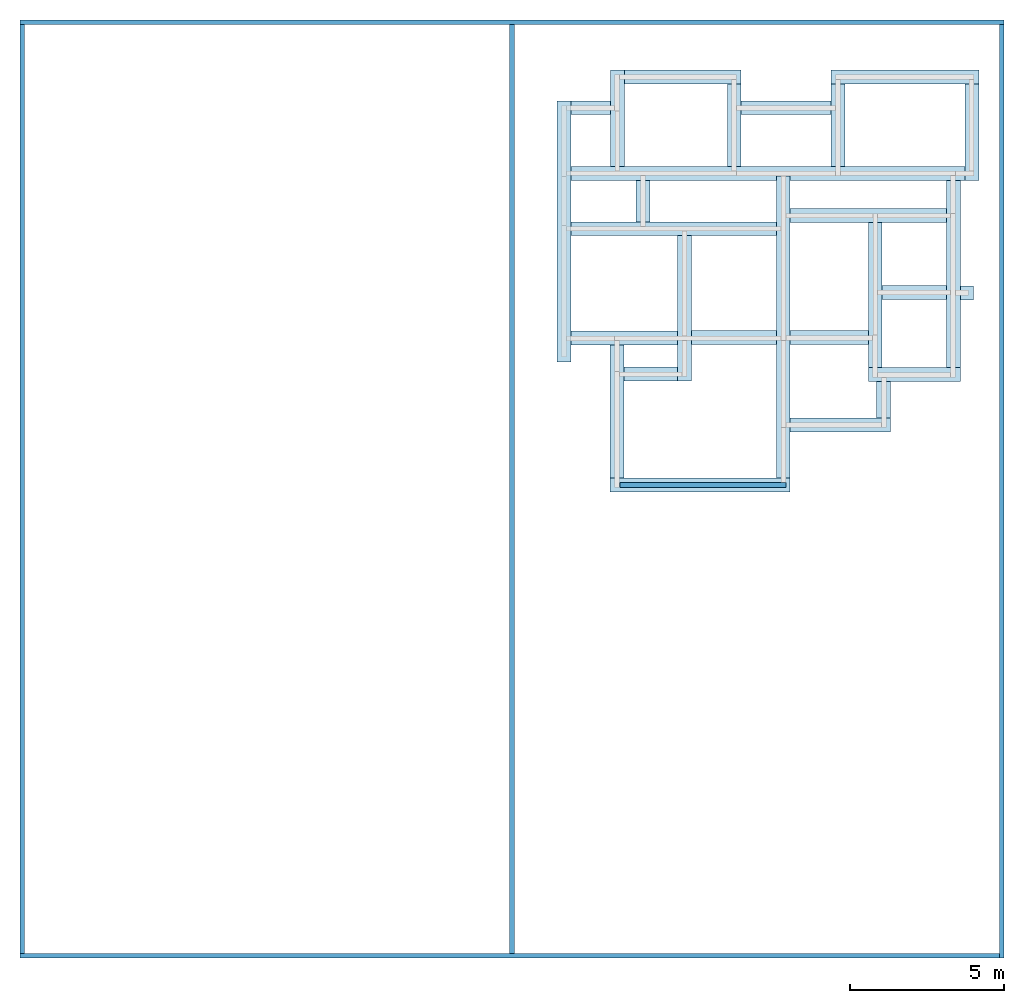
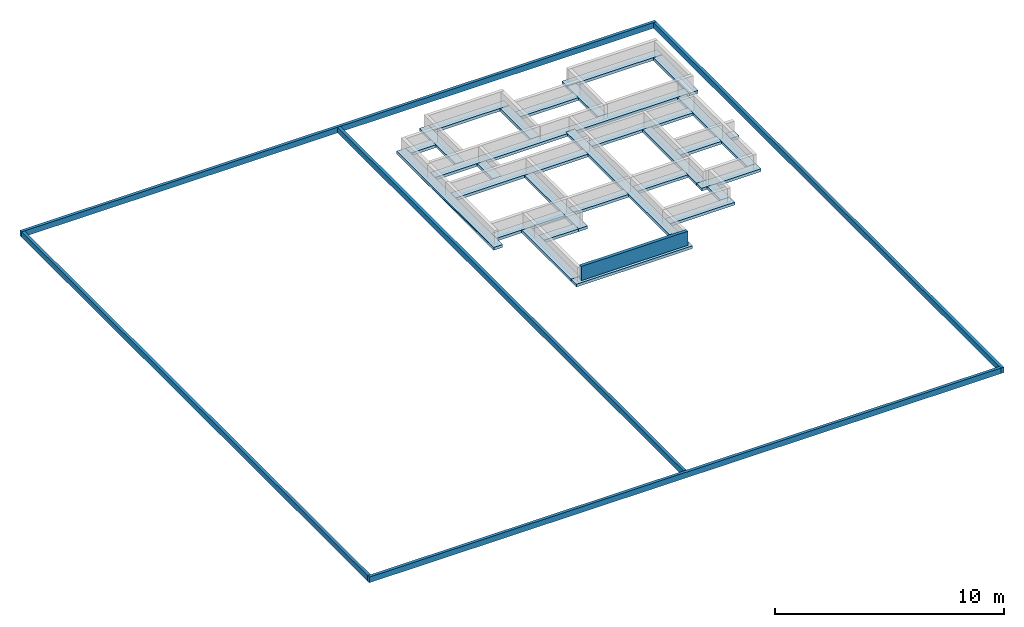
# One storey, part 1 of 2: 29 footings, 6 walls.
"""IFC4 building model written with IfcOpenShell, lengths in millimetres."""

from ifc_helpers import new_model, entity, si_unit, converted_unit, frame, origin_with_axes, origin_2d_with_axis, place, context, subcontext, project, spatial, indexed_curve, outline, extrude, polygons, material, layer, layer_set, layer_usage, type_object, element, save


model = new_model("IFC4")

# Units and contexts
model_context = context("Model", 3, precision=1e-05, world=origin_with_axes())
plan_context = context("Plan", 2, precision=1e-05, world=origin_2d_with_axis())
body_context = subcontext(model_context, "Body", "Model", "MODEL_VIEW")
ifc_project = project(units=[si_unit("LENGTHUNIT", "METRE", prefix="MILLI"), converted_unit("PLANEANGLEUNIT", "degree", entity("IfcReal", 0.0174532925199433), si_unit("PLANEANGLEUNIT", "RADIAN"), dimensions=[0, 0, 0, 0, 0, 0, 0]), si_unit("AREAUNIT", "SQUARE_METRE"), si_unit("VOLUMEUNIT", "CUBIC_METRE")], contexts=[model_context, plan_context])

# Site, building, storey
site_placement = place(None, origin_with_axes())
site = spatial("IfcSite", under=ifc_project, at=site_placement)
building_placement = place(site_placement, origin_with_axes())
building = spatial("IfcBuilding", under=site, at=building_placement, Name="Building")
storey_placement = place(building_placement, frame((0.0, 0.0, -900.000035762787), z_axis=(0.0, 0.0, 1.0), x_axis=(1.0, 0.0, 0.0)))
storey = spatial("IfcBuildingStorey", under=building, at=storey_placement, Name="FOUNDATION PLAN")

# Footings
ifc_material_1 = material(Name="Concrete - Common In-situ", Category="In-situ Concrete/ Large Precast Concrete")
footing_1_placement = place(storey_placement, frame((8774.75070953369, 14656.0354232788, -75.0000476837157), z_axis=(0.0, 0.0, 1.0), x_axis=(1.0, 0.0, 0.0)))
element("IfcFooting", 1, at=footing_1_placement, inside=storey, material=ifc_material_1, Name="Cube", PredefinedType="STRIP_FOOTING", context=body_context, shape_type="Tessellation", body=[
    polygons([(-224.999984741211, -1691.21069335938, -75.0), (-224.999984741211, 999.999877929688, -75.0), (-224.999984741211, -1691.21069335938, 75.0), (-224.999984741211, 999.999877929688, 75.0), (224.999984741211, 999.999877929688, -75.0), (224.999984741211, 999.999877929688, 75.0), (224.999984741211, -1691.21069335938, -75.0), (224.999984741211, -1691.21069335938, 75.0)], [[[3, 2, 1]], [[3, 4, 2]], [[6, 5, 2]], [[6, 2, 4]], [[6, 7, 5]], [[6, 8, 7]], [[7, 8, 3]], [[7, 3, 1]], [[1, 2, 5]], [[1, 5, 7]], [[4, 8, 6]], [[4, 3, 8]]], closed=True),
])
footing_2_placement = place(storey_placement, frame((6990.45419692993, 11664.831161499, -74.9999880790709), z_axis=(0.0, 0.0, 1.0), x_axis=(1.0, 0.0, 0.0)))
element("IfcFooting", 2, at=footing_2_placement, inside=storey, material=ifc_material_1, Name="Cube", PredefinedType="STRIP_FOOTING", context=body_context, shape_type="Tessellation", body=[
    polygons([(-224.999984741211, -8821.1494140625, -75.0), (-224.999984741211, 999.999877929688, -75.0), (-224.999984741211, -8821.1494140625, 75.0), (-224.999984741211, 999.999877929688, 75.0), (224.999984741211, 999.999877929688, -75.0), (224.999984741211, 999.999877929688, 75.0), (224.999984741211, -8821.1494140625, -75.0), (224.999984741211, -8821.1494140625, 75.0)], [[[3, 2, 1]], [[3, 4, 2]], [[6, 5, 2]], [[6, 2, 4]], [[6, 7, 5]], [[6, 8, 7]], [[7, 8, 3]], [[7, 3, 1]], [[1, 2, 5]], [[1, 5, 7]], [[4, 8, 6]], [[4, 3, 8]]], closed=True),
])
footing_3_placement = place(storey_placement, frame((13123.2786178589, 14656.0354232788, -75.0000476837157), z_axis=(0.0, 0.0, 1.0), x_axis=(1.0, 0.0, 0.0)))
element("IfcFooting", 3, at=footing_3_placement, inside=storey, material=ifc_material_1, Name="Cube", PredefinedType="STRIP_FOOTING", context=body_context, shape_type="Tessellation", body=[
    polygons([(-224.999984741211, -2141.21142578125, -75.0), (-224.999984741211, 999.999877929688, -75.0), (-224.999984741211, -2141.2109375, 75.0), (-224.999984741211, 999.999877929688, 75.0), (224.999984741211, 999.999877929688, -75.0), (224.999984741211, 999.999877929688, 75.0), (224.999984741211, -2141.21142578125, -75.0), (224.999984741211, -2141.2109375, 75.0)], [[[2, 4, 6, 5]], [[6, 8, 7, 5]], [[5, 7, 1, 2]], [[3, 8, 6, 4]], [[7, 8, 3, 1]], [[3, 4, 2, 1]]], closed=True),
])
footing_4_placement = place(storey_placement, frame((9099.74956512451, 12739.8242950439, -75.0000476837157), z_axis=(0.0, 0.0, 1.0), x_axis=(-4.37113882867379e-08, -0.999999999999999, 0.0)))
element("IfcFooting", 4, at=footing_4_placement, inside=storey, material=ifc_material_1, Name="Cube", PredefinedType="STRIP_FOOTING", context=body_context, shape_type="Tessellation", body=[
    polygons([(-225.000595092773, -9010.2783203125, -75.0), (-224.999771118164, 3798.5283203125, -75.0), (-224.999618530273, -9010.2783203125, 75.0), (-225.000106811523, 3798.5283203125, 75.0), (225.000183105469, 3798.5283203125, -75.0), (224.999862670898, 3798.5283203125, 75.0), (224.999374389648, -9010.2783203125, -75.0), (225.000335693359, -9010.2783203125, 75.0)], [[[6, 5, 2, 4]], [[5, 7, 1, 2]], [[3, 8, 6, 4]], [[8, 7, 5, 6]], [[7, 8, 3, 1]], [[2, 1, 3, 4]]], closed=True),
])
footing_5_placement = place(storey_placement, frame((-135.529160499573, 14103.9342880249, -74.9999284744262), z_axis=(0.0, 0.0, 1.0), x_axis=(1.0, 0.0, 0.0)))
element("IfcFooting", 5, at=footing_5_placement, inside=storey, material=ifc_material_1, Name="Cube", PredefinedType="STRIP_FOOTING", context=body_context, shape_type="Tessellation", body=[
    polygons([(-224.999984741211, -7482.92724609375, -75.0), (-224.999984741211, 999.999877929688, -75.0), (-224.999984741211, -7482.92724609375, 75.0), (-224.999984741211, 999.999877929688, 75.0), (224.999984741211, 999.999877929688, -75.0), (224.999984741211, 999.999877929688, 75.0), (224.999984741211, -7482.92724609375, -75.0), (224.999984741211, -7482.92724609375, 75.0)], [[[1, 4, 2]], [[3, 4, 1]], [[6, 5, 2]], [[6, 2, 4]], [[5, 8, 7]], [[6, 8, 5]], [[7, 8, 3]], [[7, 3, 1]], [[1, 2, 5]], [[1, 5, 7]], [[4, 8, 6]], [[4, 3, 8]]], closed=True),
])
footing_6_placement = place(storey_placement, frame((-135.529160499573, 14103.9342880249, -74.9999284744262), z_axis=(0.0, 0.0, 1.0), x_axis=(1.0, 0.0, 0.0)))
element("IfcFooting", 6, at=footing_6_placement, inside=storey, material=ifc_material_1, Name="Cube", PredefinedType="STRIP_FOOTING", context=body_context, shape_type="Tessellation", body=[
    polygons([(-224.999984741211, -999.999877929688, -75.0), (-224.999984741211, 999.999877929688, -75.0), (-224.999984741211, -7482.92724609375, 75.0), (-224.999984741211, 999.999877929688, 75.0), (224.999984741211, 999.999877929688, -75.0), (224.999984741211, 999.999877929688, 75.0), (224.999984741211, -999.999877929688, -75.0), (224.999984741211, -7482.92724609375, 75.0)], [[[1, 4, 2]], [[3, 4, 1]], [[6, 5, 2]], [[6, 2, 4]], [[7, 5, 6]], [[6, 8, 7]], [[3, 1, 7]], [[3, 7, 8]], [[1, 2, 5]], [[1, 5, 7]], [[4, 8, 6]], [[4, 3, 8]]], closed=True),
])
footing_7_placement = place(storey_placement, frame((1598.79803657532, 15106.0352325439, -74.9999880790709), z_axis=(0.0, 0.0, 1.0), x_axis=(1.0, 0.0, 0.0)))
element("IfcFooting", 7, at=footing_7_placement, inside=storey, material=ifc_material_1, Name="Cube", PredefinedType="STRIP_FOOTING", context=body_context, shape_type="Tessellation", body=[
    polygons([(-224.999984741211, -2141.21044921875, -75.0), (-224.999984741211, 999.999877929688, -75.0), (-224.999984741211, -2141.21044921875, 75.0), (-224.999984741211, 999.999877929688, 75.0), (224.999984741211, 999.999877929688, -75.0), (224.999984741211, 999.999877929688, 75.0), (224.999984741211, -2141.21044921875, -75.0), (224.999984741211, -2141.21044921875, 75.0)], [[[2, 4, 6, 5]], [[6, 8, 7, 5]], [[5, 7, 1, 2]], [[3, 8, 6, 4]], [[7, 8, 3, 1]], [[3, 4, 2, 1]]], closed=True),
])
footing_8_placement = place(storey_placement, frame((2823.79817962646, 15881.0358047485, -74.9999880790709), z_axis=(0.0, 0.0, 1.0), x_axis=(-4.37113882867379e-08, -0.999999999999999, 0.0)))
element("IfcFooting", 8, at=footing_8_placement, inside=storey, material=ifc_material_1, Name="Cube", PredefinedType="STRIP_FOOTING", context=body_context, shape_type="Tessellation", body=[
    polygons([(-224.999984741211, -999.999877929688, -75.0), (-225.000076293945, 2799.47338867188, -75.0), (-224.999984741211, -999.999877929688, 75.0), (-225.000076293945, 2799.47338867188, 75.0), (224.999908447266, 2799.47338867188, -75.0), (224.999908447266, 2799.47338867188, 75.0), (224.999984741211, -999.999877929688, -75.0), (224.999984741211, -999.999877929688, 75.0)], [[[3, 2, 1]], [[3, 4, 2]], [[6, 5, 2]], [[6, 2, 4]], [[6, 7, 5]], [[6, 8, 7]], [[7, 8, 3]], [[7, 3, 1]], [[1, 2, 5]], [[1, 5, 7]], [[6, 3, 8]], [[4, 3, 6]]], closed=True),
])
footing_9_placement = place(storey_placement, frame((5398.2720375061, 14656.0354232788, -74.9999880790709), z_axis=(0.0, 0.0, 1.0), x_axis=(1.0, 0.0, 0.0)))
element("IfcFooting", 9, at=footing_9_placement, inside=storey, material=ifc_material_1, Name="Cube", PredefinedType="STRIP_FOOTING", context=body_context, shape_type="Tessellation", body=[
    polygons([(-224.999984741211, -1691.21069335938, -75.0), (-224.999984741211, 999.999877929688, -75.0), (-224.999984741211, -1691.21069335938, 75.0), (-224.999984741211, 999.999877929688, 75.0), (224.999984741211, 999.999877929688, -75.0), (224.999984741211, 999.999877929688, 75.0), (224.999984741211, -1691.21069335938, -75.0), (224.999984741211, -1691.21069335938, 75.0)], [[[3, 2, 1]], [[3, 4, 2]], [[6, 5, 2]], [[6, 2, 4]], [[6, 7, 5]], [[6, 8, 7]], [[7, 8, 3]], [[7, 3, 1]], [[1, 2, 5]], [[1, 5, 7]], [[4, 8, 6]], [[4, 3, 8]]], closed=True),
])
footing_10_placement = place(storey_placement, frame((1089.47086334229, 14878.9339065552, -74.9999284744262), z_axis=(0.0, 0.0, 1.0), x_axis=(-4.37113882867379e-08, -0.999999999999999, 0.0)))
element("IfcFooting", 10, at=footing_10_placement, inside=storey, material=ifc_material_1, Name="Cube", PredefinedType="STRIP_FOOTING", context=body_context, shape_type="Tessellation", body=[
    polygons([(-224.999984741211, -999.999877929688, -75.0), (-224.999954223633, 284.327026367188, -75.0), (-224.999984741211, -999.999877929688, 75.0), (-224.999954223633, 284.327026367188, 75.0), (225.000015258789, 284.327026367188, -75.0), (225.000015258789, 284.327026367188, 75.0), (224.999984741211, -999.999877929688, -75.0), (224.999984741211, -999.999877929688, 75.0)], [[[3, 2, 1]], [[3, 4, 2]], [[6, 5, 2]], [[6, 2, 4]], [[6, 7, 5]], [[6, 8, 7]], [[7, 8, 3]], [[7, 3, 1]], [[2, 5, 7]], [[2, 7, 1]], [[4, 3, 8]], [[6, 4, 8]]], closed=True),
])
footing_11_placement = place(storey_placement, frame((8636.25144958496, 11373.3215332031, -74.9999880790709), z_axis=(0.0, 0.0, 1.0), x_axis=(-4.37113882867379e-08, -0.999999999999999, 0.0)))
element("IfcFooting", 11, at=footing_11_placement, inside=storey, material=ifc_material_1, Name="Cube", PredefinedType="STRIP_FOOTING", context=body_context, shape_type="Tessellation", body=[
    polygons([(-224.999954223633, -1420.79650878906, -75.0), (-225.000106811523, 3662.02978515625, -75.0), (-225.000106811523, 3662.02880859375, 75.0), (-224.999954223633, -1420.79650878906, 75.0), (224.99983215332, 3662.02880859375, 75.0), (224.99983215332, 3662.02978515625, -75.0), (224.999984741211, -1420.79650878906, -75.0), (224.999984741211, -1420.79650878906, 75.0)], [[[1, 3, 2]], [[4, 3, 1]], [[5, 6, 2]], [[5, 2, 3]], [[5, 7, 6]], [[5, 8, 7]], [[7, 8, 4]], [[7, 4, 1]], [[6, 7, 1]], [[2, 6, 1]], [[5, 3, 4]], [[5, 4, 8]]], closed=True),
])
footing_12_placement = place(storey_placement, frame((8486.24897003174, 8873.00109863281, -74.9999880790709), z_axis=(0.0, 0.0, 1.0), x_axis=(7.54979012640431e-08, -0.999999999999997, 0.0)))
element("IfcFooting", 12, at=footing_12_placement, inside=storey, material=ifc_material_1, Name="Cube", PredefinedType="STRIP_FOOTING", context=body_context, shape_type="Tessellation", body=[
    polygons([(-225.000106811523, 1720.51416015625, -75.0), (-225.000106811523, 3812.03247070312, -75.0), (-225.000106811523, 1720.51416015625, 75.0), (-225.000106811523, 3812.03125, 75.0), (224.999862670898, 3812.03247070312, -75.0), (224.999862670898, 3812.03125, 75.0), (224.999862670898, 1720.51416015625, -75.0), (224.999862670898, 1720.51416015625, 75.0)], [[[2, 4, 6, 5]], [[8, 7, 5, 6]], [[5, 7, 1, 2]], [[3, 8, 6, 4]], [[8, 3, 1, 7]], [[4, 2, 1, 3]]], closed=True),
])
footing_13_placement = place(storey_placement, frame((1510.26773452759, 10943.3317184448, -74.9998688697814), z_axis=(0.0, 0.0, 1.0), x_axis=(-4.37113882867379e-08, -0.999999999999999, 0.0)))
element("IfcFooting", 13, at=footing_13_placement, inside=storey, material=ifc_material_1, Name="Cube", PredefinedType="STRIP_FOOTING", context=body_context, shape_type="Tessellation", body=[
    polygons([(-224.999969482422, -1420.79663085938, -75.0), (-225.000152587891, 5255.18701171875, -75.0), (-224.999969482422, -1420.79663085938, 75.0), (-225.000152587891, 5255.185546875, 75.0), (224.999801635742, 5255.18701171875, -75.0), (224.999801635742, 5255.185546875, 75.0), (225.0, -1420.79663085938, -75.0), (225.0, -1420.79663085938, 75.0)], [[[1, 4, 2]], [[3, 4, 1]], [[6, 5, 2]], [[6, 2, 4]], [[6, 7, 5]], [[6, 8, 7]], [[7, 8, 3]], [[7, 3, 1]], [[5, 7, 1]], [[2, 5, 1]], [[6, 4, 3]], [[6, 3, 8]]], closed=True),
])
footing_14_placement = place(storey_placement, frame((9981.76288604736, 10148.3211517334, -74.9999880790709), z_axis=(0.0, 0.0, 1.0), x_axis=(1.0, 0.0, 0.0)))
element("IfcFooting", 14, at=footing_14_placement, inside=storey, material=ifc_material_1, Name="Cube", PredefinedType="STRIP_FOOTING", context=body_context, shape_type="Tessellation", body=[
    polygons([(-224.999984741211, -3720.31640625, -75.0), (-224.999984741211, 999.999877929688, -75.0), (-224.999984741211, -3720.31640625, 75.0), (-224.999984741211, 999.999877929688, 75.0), (224.999984741211, 999.999877929688, -75.0), (224.999984741211, 999.999877929688, 75.0), (224.999984741211, -3720.31640625, -75.0), (224.999984741211, -3720.31640625, 75.0)], [[[3, 2, 1]], [[3, 4, 2]], [[6, 5, 2]], [[6, 2, 4]], [[6, 7, 5]], [[6, 8, 7]], [[7, 8, 3]], [[7, 3, 1]], [[2, 5, 7]], [[2, 7, 1]], [[6, 4, 3]], [[6, 3, 8]]], closed=True),
])
footing_15_placement = place(storey_placement, frame((12523.2810974121, 11514.8239135742, -74.9999880790709), z_axis=(0.0, 0.0, 1.0), x_axis=(1.0, 0.0, 0.0)))
element("IfcFooting", 15, at=footing_15_placement, inside=storey, material=ifc_material_1, Name="Cube", PredefinedType="STRIP_FOOTING", context=body_context, shape_type="Tessellation", body=[
    polygons([(-224.999984741211, -5086.81884765625, -75.0), (-224.999984741211, 999.999877929688, -75.0), (-224.999984741211, -5086.81884765625, 75.0), (-224.999984741211, 999.999877929688, 75.0), (224.999984741211, 999.999877929688, -75.0), (224.999984741211, 999.999877929688, 75.0), (224.999984741211, -5086.81884765625, -75.0), (224.999984741211, -5086.81884765625, 75.0)], [[[3, 2, 1]], [[3, 4, 2]], [[6, 5, 2]], [[6, 2, 4]], [[6, 7, 5]], [[6, 8, 7]], [[7, 8, 3]], [[7, 3, 1]], [[2, 5, 7]], [[2, 7, 1]], [[6, 4, 3]], [[6, 3, 8]]], closed=True),
])
footing_16_placement = place(storey_placement, frame((8486.24897003174, 6203.00436019897, -74.9999880790709), z_axis=(0.0, 0.0, 1.0), x_axis=(-4.37113882867379e-08, -0.999999999999999, 0.0)))
element("IfcFooting", 16, at=footing_16_placement, inside=storey, material=ifc_material_1, Name="Cube", PredefinedType="STRIP_FOOTING", context=body_context, shape_type="Tessellation", body=[
    polygons([(-225.000106811523, 1270.51342773438, -75.0), (-225.000106811523, 4262.03271484375, -75.0), (-225.000106811523, 1270.51342773438, 75.0), (-225.000106811523, 4262.03173828125, 75.0), (224.999847412109, 4262.03271484375, -75.0), (224.999847412109, 4262.03173828125, 75.0), (224.999877929688, 1270.51342773438, -75.0), (224.999877929688, 1270.51342773438, 75.0)], [[[1, 4, 2]], [[3, 4, 1]], [[6, 5, 2]], [[6, 2, 4]], [[6, 7, 5]], [[6, 8, 7]], [[7, 8, 3]], [[7, 3, 1]], [[5, 7, 1]], [[2, 5, 1]], [[6, 4, 3]], [[6, 3, 8]]], closed=True),
])
footing_17_placement = place(storey_placement, frame((3780.96985816956, 9718.3313369751, -74.9998688697814), z_axis=(0.0, 0.0, 1.0), x_axis=(1.0, 0.0, 0.0)))
element("IfcFooting", 17, at=footing_17_placement, inside=storey, material=ifc_material_1, Name="Cube", PredefinedType="STRIP_FOOTING", context=body_context, shape_type="Tessellation", body=[
    polygons([(-224.999984741211, -3720.31640625, -75.0), (-224.999984741211, 999.999877929688, -75.0), (-224.999984741211, -3720.31640625, 75.0), (-224.999984741211, 999.999877929688, 75.0), (224.999984741211, 999.999877929688, -75.0), (224.999984741211, 999.999877929688, 75.0), (224.999984741211, -3720.31640625, -75.0), (224.999984741211, -3720.31640625, 75.0)], [[[3, 2, 1]], [[3, 4, 2]], [[6, 5, 2]], [[6, 2, 4]], [[6, 7, 5]], [[6, 8, 7]], [[7, 8, 3]], [[7, 3, 1]], [[2, 5, 7]], [[2, 7, 1]], [[6, 4, 3]], [[6, 3, 8]]], closed=True),
])
footing_18_placement = place(storey_placement, frame((1510.26678085327, 7388.68141174316, -74.9999880790709), z_axis=(0.0, 0.0, 1.0), x_axis=(-4.37113882867379e-08, -0.999999999999999, 0.0)))
element("IfcFooting", 18, at=footing_18_placement, inside=storey, material=ifc_material_1, Name="Cube", PredefinedType="STRIP_FOOTING", context=body_context, shape_type="Tessellation", body=[
    polygons([(-224.999969482422, -1420.79663085938, -75.0), (-225.000030517578, 2045.70397949219, -75.0), (-224.999969482422, -1420.79663085938, 75.0), (-225.000030517578, 2045.70251464844, 75.0), (224.999938964844, 2045.70397949219, -75.0), (224.999938964844, 2045.70251464844, 75.0), (225.0, -1420.79663085938, -75.0), (225.0, -1420.79663085938, 75.0)], [[[1, 4, 2]], [[3, 4, 1]], [[6, 5, 2]], [[6, 2, 4]], [[6, 7, 5]], [[6, 8, 7]], [[7, 8, 3]], [[7, 3, 1]], [[5, 7, 1]], [[2, 5, 1]], [[6, 4, 3]], [[6, 3, 8]]], closed=True),
])
footing_19_placement = place(storey_placement, frame((4719.74992752075, 7404.99973297119, -74.9999880790709), z_axis=(0.0, 0.0, 1.0), x_axis=(-4.37113882867379e-08, -0.999999999999999, 0.0)))
element("IfcFooting", 19, at=footing_19_placement, inside=storey, material=ifc_material_1, Name="Cube", PredefinedType="STRIP_FOOTING", context=body_context, shape_type="Tessellation", body=[
    polygons([(-225.0, -713.779907226562, -75.0), (-225.000030517578, 2045.70397949219, -75.0), (-225.0, -713.779907226562, 75.0), (-225.000030517578, 2045.70251464844, 75.0), (224.999938964844, 2045.70397949219, -75.0), (224.999938964844, 2045.70251464844, 75.0), (224.999969482422, -713.779907226562, -75.0), (224.999969482422, -713.779907226562, 75.0)], [[[1, 4, 2]], [[3, 4, 1]], [[6, 5, 2]], [[6, 2, 4]], [[6, 7, 5]], [[6, 8, 7]], [[7, 8, 3]], [[7, 3, 1]], [[5, 7, 1]], [[2, 5, 1]], [[6, 4, 3]], [[6, 3, 8]]], closed=True),
])
footing_20_placement = place(storey_placement, frame((1584.99681949615, 6179.99982833862, -74.9999880790709), z_axis=(0.0, 0.0, 1.0), x_axis=(1.0, 0.0, 0.0)))
element("IfcFooting", 20, at=footing_20_placement, inside=storey, material=ifc_material_1, Name="Cube", PredefinedType="STRIP_FOOTING", context=body_context, shape_type="Tessellation", body=[
    polygons([(-224.999984741211, -3336.31811523438, -75.0), (-224.999984741211, 999.999877929688, -75.0), (-224.999984741211, -3336.31811523438, 75.0), (-224.999984741211, 999.999877929688, 75.0), (224.999984741211, 999.999877929688, -75.0), (224.999984741211, 999.999877929688, 75.0), (224.999984741211, -3336.31811523438, -75.0), (224.999984741211, -3336.31811523438, 75.0)], [[[3, 2, 1]], [[3, 4, 2]], [[6, 5, 2]], [[6, 2, 4]], [[6, 7, 5]], [[6, 8, 7]], [[7, 8, 3]], [[7, 3, 1]], [[1, 2, 5]], [[1, 5, 7]], [[4, 8, 6]], [[4, 3, 8]]], closed=True),
])
footing_21_placement = place(storey_placement, frame((-47.0151901245117, 6225.18110275269, -74.9999880790709), z_axis=(0.0, 0.0, 1.0), x_axis=(-4.37113882867379e-08, -0.999999999999999, 0.0)))
element("IfcFooting", 21, at=footing_21_placement, inside=storey, material=ifc_material_1, Name="Cube", PredefinedType="STRIP_FOOTING", context=body_context, shape_type="Tessellation", body=[
    polygons([(-225.000106811523, 1857.01196289062, -75.0), (-225.000106811523, 3602.98461914062, -75.0), (-225.000106811523, 1857.01196289062, 75.0), (-225.000106811523, 3602.9833984375, 75.0), (224.999877929688, 3602.98461914062, -75.0), (224.999877929688, 3602.9833984375, 75.0), (224.999862670898, 1857.01196289062, -75.0), (224.999862670898, 1857.01196289062, 75.0)], [[[1, 3, 4]], [[1, 4, 2]], [[6, 5, 2]], [[6, 2, 4]], [[6, 7, 5]], [[6, 8, 7]], [[1, 7, 8]], [[1, 8, 3]], [[2, 5, 7]], [[2, 7, 1]], [[4, 3, 8]], [[6, 4, 8]]], closed=True),
])
footing_22_placement = place(storey_placement, frame((4719.74992752075, 2618.68095397949, -74.9999880790709), z_axis=(0.0, 0.0, 1.0), x_axis=(-4.37113882867379e-08, -0.999999999999999, 0.0)))
element("IfcFooting", 22, at=footing_22_placement, inside=storey, material=ifc_material_1, Name="Cube", PredefinedType="STRIP_FOOTING", context=body_context, shape_type="Tessellation", body=[
    polygons([(-224.999877929688, -3359.75268554688, -75.0), (-225.000045776367, 2495.7041015625, -75.0), (-224.999877929688, -3359.75268554688, 75.0), (-225.000045776367, 2495.70263671875, 75.0), (224.999923706055, 2495.7041015625, -75.0), (224.999923706055, 2495.70263671875, 75.0), (225.000106811523, -3359.75268554688, -75.0), (225.000106811523, -3359.75268554688, 75.0)], [[[1, 4, 2]], [[3, 4, 1]], [[6, 5, 2]], [[6, 2, 4]], [[6, 7, 5]], [[6, 8, 7]], [[7, 8, 3]], [[7, 3, 1]], [[5, 7, 1]], [[2, 5, 1]], [[6, 4, 3]], [[6, 3, 8]]], closed=True),
])
footing_23_placement = place(storey_placement, frame((7711.05813980103, 7404.99973297119, -74.9999880790709), z_axis=(0.0, 0.0, 1.0), x_axis=(-4.37113882867379e-08, -0.999999999999999, 0.0)))
element("IfcFooting", 23, at=footing_23_placement, inside=storey, material=ifc_material_1, Name="Cube", PredefinedType="STRIP_FOOTING", context=body_context, shape_type="Tessellation", body=[
    polygons([(-225.000015258789, -495.603973388672, -75.0), (-225.000030517578, 2045.70397949219, -75.0), (-225.000015258789, -495.603973388672, 75.0), (-225.000030517578, 2045.70251464844, 75.0), (224.999938964844, 2045.70397949219, -75.0), (224.999938964844, 2045.70251464844, 75.0), (224.999954223633, -495.603973388672, -75.0), (224.999954223633, -495.603973388672, 75.0)], [[[1, 4, 2]], [[3, 4, 1]], [[6, 5, 2]], [[6, 2, 4]], [[6, 7, 5]], [[6, 8, 7]], [[7, 8, 3]], [[7, 3, 1]], [[5, 7, 1]], [[2, 5, 1]], [[6, 4, 3]], [[6, 3, 8]]], closed=True),
])
footing_24_placement = place(storey_placement, frame((2430.97066879272, 12859.5428466797, -74.9999880790709), z_axis=(0.0, 0.0, 1.0), x_axis=(1.0, 0.0, 0.0)))
element("IfcFooting", 24, at=footing_24_placement, inside=storey, material=ifc_material_1, Name="Cube", PredefinedType="STRIP_FOOTING", context=body_context, shape_type="Tessellation", body=[
    polygons([(-224.999984741211, -1691.21069335938, -75.0), (-224.999984741211, -344.718872070312, -75.0), (-224.999984741211, -1691.21069335938, 75.0), (-224.999984741211, -344.718872070312, 75.0), (224.999984741211, -344.718872070312, -75.0), (224.999984741211, -344.718872070312, 75.0), (224.999984741211, -1691.21069335938, -75.0), (224.999984741211, -1691.21069335938, 75.0)], [[[3, 2, 1]], [[3, 4, 2]], [[6, 5, 2]], [[6, 2, 4]], [[6, 7, 5]], [[6, 8, 7]], [[7, 8, 3]], [[7, 3, 1]], [[2, 5, 7]], [[2, 7, 1]], [[6, 4, 3]], [[6, 3, 8]]], closed=True),
])
footing_25_placement = place(storey_placement, frame((8370.41187286377, 4568.67980957031, -74.9999880790709), z_axis=(0.0, 0.0, 1.0), x_axis=(7.54979012640431e-08, -0.999999999999997, 0.0)))
element("IfcFooting", 25, at=footing_25_placement, inside=storey, material=ifc_material_1, Name="Cube", PredefinedType="STRIP_FOOTING", context=body_context, shape_type="Tessellation", body=[
    polygons([(-224.999984741211, 2109.3505859375, -75.0), (224.999954223633, 2109.3505859375, -75.0), (-225.0, 2109.3505859375, 75.0), (224.999938964844, 2109.3505859375, 75.0), (224.999893188477, -1154.95764160156, 75.0), (224.999893188477, -1154.95764160156, -75.0), (-225.000045776367, -1154.95764160156, -75.0), (-225.000045776367, -1154.95764160156, 75.0)], [[[8, 7, 6, 5]], [[7, 8, 3, 1]], [[5, 6, 2, 4]], [[6, 7, 1, 2]], [[4, 3, 8, 5]], [[4, 2, 1, 3]]], closed=True),
])
footing_26_placement = place(storey_placement, frame((10254.7626495361, 6484.89093780518, -74.9999880790709), z_axis=(0.0, 0.0, 1.0), x_axis=(1.0, 0.0, 0.0)))
element("IfcFooting", 26, at=footing_26_placement, inside=storey, material=ifc_material_1, Name="Cube", PredefinedType="STRIP_FOOTING", context=body_context, shape_type="Tessellation", body=[
    polygons([(224.999969482422, -506.886383056641, -75.0), (224.999969482422, -1691.21069335938, -75.0), (-224.999969482422, -1691.21069335938, -75.0), (-224.999969482422, -506.886383056641, -75.0), (224.999969482422, -506.886383056641, 75.0), (224.999969482422, -1691.21069335938, 75.0), (-224.999969482422, -1691.21069335938, 75.0), (-224.999969482422, -506.886383056641, 75.0)], [[[4, 1, 2]], [[4, 2, 3]], [[5, 6, 2]], [[5, 2, 1]], [[3, 7, 8]], [[3, 8, 4]], [[5, 8, 7]], [[5, 7, 6]], [[2, 6, 7]], [[2, 7, 3]], [[5, 1, 4]], [[5, 4, 8]]], closed=True),
])
footing_27_placement = place(storey_placement, frame((11477.7679443359, 8857.99789428711, -74.9999880790709), z_axis=(0.0, 0.0, 1.0), x_axis=(1.94707183709394e-07, -0.999999999999981, 0.0)))
element("IfcFooting", 27, at=footing_27_placement, inside=storey, material=ifc_material_1, Name="Cube", PredefinedType="STRIP_FOOTING", context=body_context, shape_type="Tessellation", body=[
    polygons([(-225.000289916992, 1690.50939941406, -75.0), (224.999633789062, 1690.50939941406, -75.0), (-225.000289916992, 1690.50866699219, 75.0), (224.999633789062, 1690.50866699219, 75.0), (224.999862670898, 1270.51330566406, 75.0), (224.999862670898, 1270.51330566406, -75.0), (-225.000106811523, 1270.51330566406, -75.0), (-225.000106811523, 1270.51330566406, 75.0)], [[[4, 2, 1]], [[4, 1, 3]], [[4, 5, 6]], [[4, 6, 2]], [[7, 2, 6]], [[1, 2, 7]], [[8, 5, 4]], [[3, 8, 4]], [[6, 5, 8]], [[6, 8, 7]], [[7, 3, 1]], [[8, 3, 7]]], closed=True),
])
footing_28_placement = place(storey_placement, frame((8128.9234161377, 14878.9339065552, -74.9999284744262), z_axis=(0.0, 0.0, 1.0), x_axis=(7.54979012640431e-08, -0.999999999999997, 0.0)))
element("IfcFooting", 28, at=footing_28_placement, inside=storey, material=ifc_material_1, Name="Cube", PredefinedType="STRIP_FOOTING", context=body_context, shape_type="Tessellation", body=[
    polygons([(-225.000106811523, -2505.6513671875, -75.0), (-224.999938964844, 420.826416015625, -75.0), (-225.000106811523, -2505.6513671875, 75.0), (-224.999938964844, 420.826416015625, 75.0), (225.000030517578, 420.826416015625, -75.0), (225.000030517578, 420.826416015625, 75.0), (224.999862670898, -2505.6513671875, -75.0), (224.999862670898, -2505.6513671875, 75.0)], [[[7, 1, 2, 5]], [[6, 8, 7, 5]], [[3, 4, 2, 1]], [[6, 4, 3, 8]], [[3, 1, 7, 8]], [[2, 4, 6, 5]]], closed=True),
])
footing_29_placement = place(storey_placement, frame((10005.5999755859, 15881.0358047485, -74.9999880790709), z_axis=(0.0, 0.0, 1.0), x_axis=(7.54979012640431e-08, -0.999999999999997, 0.0)))
element("IfcFooting", 29, at=footing_29_placement, inside=storey, material=ifc_material_1, Name="Cube", PredefinedType="STRIP_FOOTING", context=body_context, shape_type="Tessellation", body=[
    polygons([(-225.000045776367, -1455.84936523438, -75.0), (-224.999984741211, -1455.84948730469, 75.0), (-224.999969482422, 3342.67895507812, -75.0), (-225.000015258789, 3342.67895507812, 75.0), (224.999923706055, 3342.67895507812, 75.0), (224.999984741211, 3342.67895507812, -75.0), (224.999862670898, -1455.84936523438, -75.0), (224.999923706055, -1455.84948730469, 75.0)], [[[2, 3, 1]], [[2, 4, 3]], [[3, 5, 6]], [[3, 4, 5]], [[5, 7, 6]], [[5, 8, 7]], [[2, 7, 8]], [[2, 1, 7]], [[3, 6, 1]], [[6, 7, 1]], [[5, 2, 8]], [[5, 4, 2]]], closed=True),
])

# Walls
ifc_material_2 = material(Category="Masonry")
ifc_layer_1 = layer(ifc_material_2, 150.0, Priority=1)
ifc_layer_set_1 = layer_set([ifc_layer_1], Name="WAL-SLD-CRE-1LYR")
ifc_layer_usage_1 = layer_usage(ifc_layer_set_1, "AXIS2", "POSITIVE", 0.0)
wall_type_1 = type_object("IfcWallType", Name="WAL150SLD_CRE", PredefinedType="SOLIDWALL", material=ifc_layer_set_1)
wall_1_placement = place(storey_placement, frame((-17824.800491333, 17582.7827453613, 0.0), z_axis=(0.0, 0.0, 1.0), x_axis=(1.0, 0.0, 0.0)))
element("IfcWall", 30, at=wall_1_placement, inside=storey, type_object=wall_type_1, material=ifc_layer_usage_1, Name="Wall.003", PredefinedType="USERDEFINED", context=body_context, shape_type="SweptSolid", body=[
    extrude(outline(indexed_curve([(0.0, 0.0), (0.0, 150.0), (31991.8879717358, 150.0), (31991.8879717358, 0.0), (0.0, 0.0)], self_intersect=False)), origin_with_axes(), (0.0, 0.0, 1.0), 300.000011920929),
])
ifc_layer_usage_2 = layer_usage(ifc_layer_set_1, "AXIS2", "POSITIVE", 0.0)
wall_2_placement = place(storey_placement, frame((14017.0860290527, 17582.7827453613, 1.11022302462516e-13), z_axis=(0.0, 0.0, 1.0), x_axis=(-5.2054855359522e-07, -0.999999999999865, 0.0)))
element("IfcWall", 31, at=wall_2_placement, inside=storey, type_object=wall_type_1, material=ifc_layer_usage_2, Name="Wall.002", PredefinedType="USERDEFINED", context=body_context, shape_type="SweptSolid", body=[
    extrude(outline(indexed_curve([(0.0, 0.0), (0.0, 150.0), (30346.5689264162, 150.0), (30346.5689264162, 0.0), (0.0, 0.0)], self_intersect=False)), origin_with_axes(), (0.0, 0.0, 1.0), 300.000011920929),
])
ifc_layer_usage_3 = layer_usage(ifc_layer_set_1, "AXIS2", "POSITIVE", 0.0)
wall_3_placement = place(storey_placement, frame((-17824.800491333, 17582.7827453613, 0.0), z_axis=(0.0, 0.0, 1.0), x_axis=(-5.2054855359522e-07, -0.999999999999865, 0.0)))
element("IfcWall", 32, at=wall_3_placement, inside=storey, type_object=wall_type_1, material=ifc_layer_usage_3, Name="Wall.001", PredefinedType="USERDEFINED", context=body_context, shape_type="SweptSolid", body=[
    extrude(outline(indexed_curve([(0.0, 0.0), (0.0, 150.0), (30196.5545912099, 150.0), (30196.5545912099, 0.0), (0.0, 0.0)], self_intersect=False)), origin_with_axes(), (0.0, 0.0, 1.0), 300.000011920929),
])
ifc_layer_usage_4 = layer_usage(ifc_layer_set_1, "AXIS2", "POSITIVE", 0.0)
wall_4_placement = place(storey_placement, frame((14017.0860290527, -12613.7866973877, 1.11022302462516e-13), z_axis=(0.0, 0.0, 1.0), x_axis=(-0.999999999999924, 3.89414367418765e-07, 0.0)))
element("IfcWall", 33, at=wall_4_placement, inside=storey, type_object=wall_type_1, material=ifc_layer_usage_4, Name="Wall.004", PredefinedType="USERDEFINED", context=body_context, shape_type="SweptSolid", body=[
    extrude(outline(indexed_curve([(0.0, 0.0), (0.0, 150.0), (31841.8888225748, 150.0), (31841.8888225748, 0.0), (0.0, 0.0)], self_intersect=False)), origin_with_axes(), (0.0, 0.0, 1.0), 300.000011920929),
])
ifc_layer_usage_5 = layer_usage(ifc_layer_set_1, "AXIS2", "POSITIVE", 0.0)
wall_5_placement = place(storey_placement, frame((-1903.85723114014, 17582.7827453613, 1.11022302462516e-13), z_axis=(0.0, 0.0, 1.0), x_axis=(-5.2054855359522e-07, -0.999999999999865, 0.0)))
element("IfcWall", 34, at=wall_5_placement, inside=storey, type_object=wall_type_1, material=ifc_layer_usage_5, Name="WAL150HOL_2Pnt", context=body_context, shape_type="SweptSolid", body=[
    extrude(outline(indexed_curve([(0.0, 0.0), (0.0, 150.0), (30196.563686889, 150.0), (30196.563686889, 0.0), (0.0, 0.0)], self_intersect=False)), origin_with_axes(), (0.0, 0.0, 1.0), 300.000011920929),
])
ifc_material_3 = material(Name="Paint", Category="Surface Finishes")
ifc_layer_2 = layer(ifc_material_3, 1.0, Name="1-Paint", Category="Finish", Priority=4)
ifc_material_4 = material(Name="Render - Mortar", Category="Surface Finishes")
ifc_layer_3 = layer(ifc_material_4, 12.5, Name="2-Render Mortar", Category="Substrate", Priority=2)
ifc_layer_4 = layer(ifc_material_2, 150.0, Name="3", Priority=1)
ifc_layer_set_2 = layer_set([ifc_layer_2, ifc_layer_3, ifc_layer_4], Name="WAL-SLD-PNT-3LYR")
ifc_layer_usage_6 = layer_usage(ifc_layer_set_2, "AXIS2", "POSITIVE", 0.0)
wall_type_2 = type_object("IfcWallType", PredefinedType="SOLIDWALL", material=ifc_layer_set_2)
wall_6_placement = place(storey_placement, frame((1689.99671936035, 2530.18140792847, 0.0), z_axis=(0.0, 0.0, 1.0), x_axis=(1.0, 0.0, 0.0)))
element("IfcWall", 35, at=wall_6_placement, inside=storey, type_object=wall_type_2, material=ifc_layer_usage_6, Name="WAL150HOL_2Pnt", context=body_context, shape_type="SweptSolid", body=[
    extrude(outline(indexed_curve([(0.0, 0.0), (0.0, 163.5), (5383.26125357512, 163.5), (5383.26125357512, 0.0), (0.0, 0.0)], self_intersect=False)), origin_with_axes(), (0.0, 0.0, 1.0), 750.000059604645),
])

save(model, "model.ifc")
